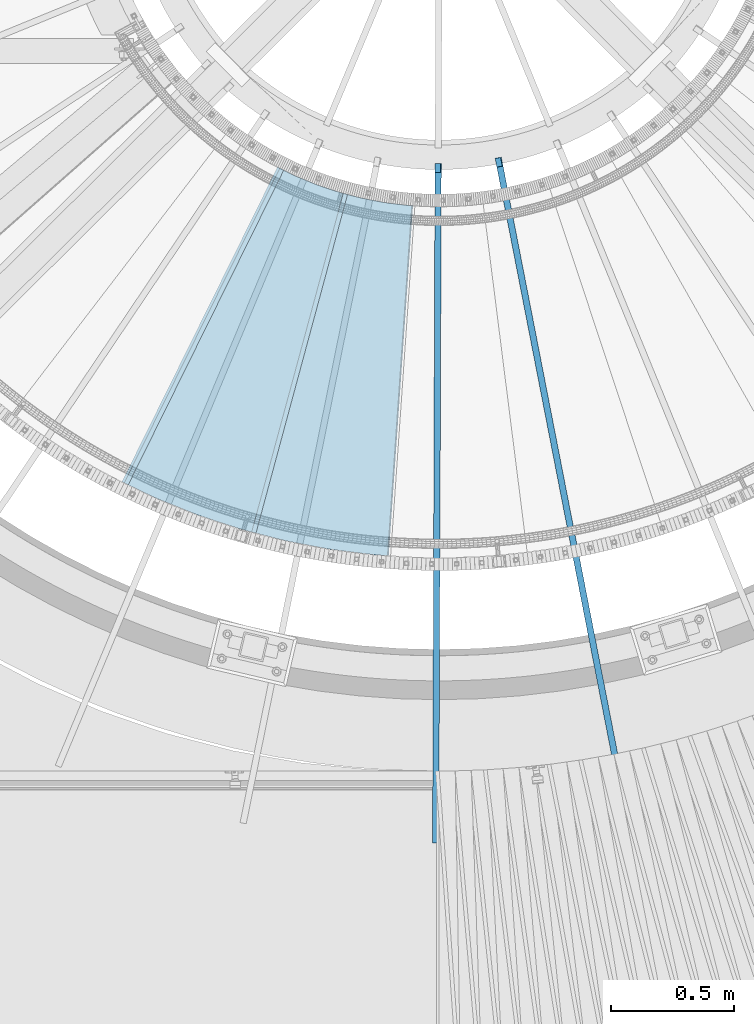
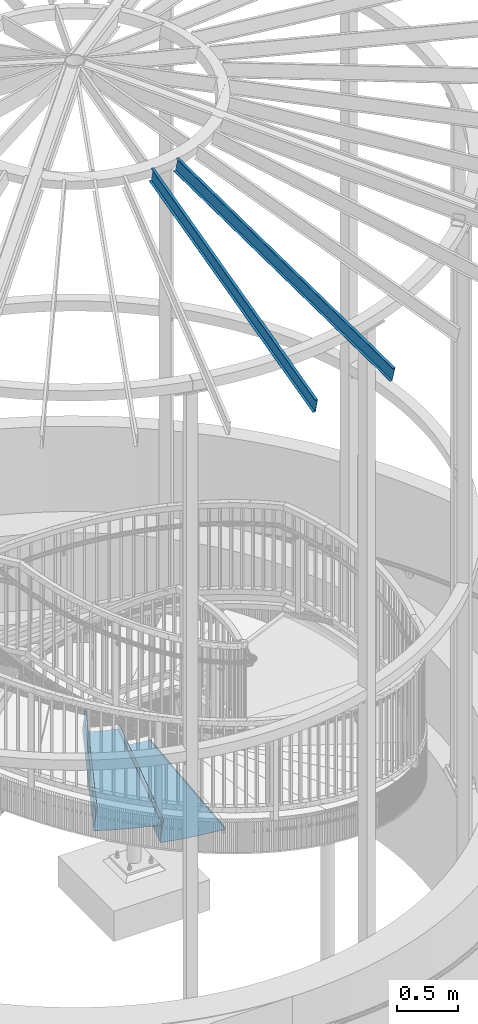
# One storey, part 340 of 975: 4 beams.
"""IFC2X3 building model written with IfcOpenShell, lengths in millimetres."""

import ifcopenshell
import ifcopenshell.guid

model = None  # the IFC model being written
_history = None  # IfcOwnerHistory: only IFC2X3 demands one
_inside = {}  # id of a spatial element -> (the spatial element, [elements in it])
_under = {}  # id of a project, library or spatial element -> (it, [spatial elements below it])
_declared = {}  # id of a project -> (the project, [libraries it declares])
_typed = {}  # id of a type object -> (the type object, [elements of that type])
_made_of = {}  # id of a material, layer set ... -> (it, [elements and type objects made of it])


def new_model(schema):
    """Start an empty IFC model of exactly this schema.

    Asked for "IFC4X3", IfcOpenShell would pick the latest addendum, in which some entities
    have other attributes; the version numbers below select the first issue.
    IFC2X3 requires an IfcOwnerHistory on every rooted entity: one is made here for all.
    """
    global model, _history
    if schema == "IFC4X3":
        model = ifcopenshell.file(schema_version=(4, 3, 0, 0))
    else:
        model = ifcopenshell.file(schema=schema)
    _inside.clear()
    _under.clear()
    _declared.clear()
    _typed.clear()
    _made_of.clear()
    _history = None
    if model.schema == "IFC2X3":
        org = make("IfcOrganization", Name="unknown")
        user = make(
            "IfcPersonAndOrganization",
            ThePerson=make("IfcPerson", FamilyName="unknown"),
            TheOrganization=org,
        )
        app = make(
            "IfcApplication",
            ApplicationDeveloper=org,
            Version="unknown",
            ApplicationFullName="unknown",
            ApplicationIdentifier="unknown",
        )
        _history = make(
            "IfcOwnerHistory",
            OwningUser=user,
            OwningApplication=app,
            ChangeAction="ADDED",
            CreationDate=0,
        )
    return model


def make(cls, **values):
    """One entity of the class cls with the attributes given. An attribute that is None is left unset."""
    return model.create_entity(
        cls, **{name: value for name, value in values.items() if value is not None}
    )


def rooted(cls, **values):
    """An entity with a GlobalId (a new one), such as an element, a storey or a relation."""
    return make(cls, GlobalId=ifcopenshell.guid.new(), OwnerHistory=_history, **values)


def si_unit(unit_type, name, prefix=None):
    """IfcSIUnit, for example si_unit("LENGTHUNIT", "METRE", prefix="MILLI")."""
    return make("IfcSIUnit", UnitType=unit_type, Prefix=prefix, Name=name)


def assignment(units):
    """IfcUnitAssignment: the units of a project."""
    return None if units is None else make("IfcUnitAssignment", Units=units)


def point(xyz):
    """IfcCartesianPoint."""
    return None if xyz is None else make("IfcCartesianPoint", Coordinates=xyz)


def direction(xyz):
    """IfcDirection."""
    return None if xyz is None else make("IfcDirection", DirectionRatios=xyz)


def frame(location, z_axis=None, x_axis=None):
    """IfcAxis2Placement3D, a coordinate frame: its origin and axes. An axis left out is left unset."""
    return make(
        "IfcAxis2Placement3D",
        Location=point(location),
        Axis=direction(z_axis),
        RefDirection=direction(x_axis),
    )


def origin_with_axes():
    """The frame at (0, 0, 0) with the z axis (0, 0, 1) and the x axis (1, 0, 0) written out."""
    return frame((0.0, 0.0, 0.0), z_axis=(0.0, 0.0, 1.0), x_axis=(1.0, 0.0, 0.0))


def place(relative_to, where):
    """IfcLocalPlacement: puts the frame where relative to a parent placement (None: the world)."""
    return make(
        "IfcLocalPlacement", PlacementRelTo=relative_to, RelativePlacement=where
    )


def context(
    kind, dimensions, precision=None, world=None, true_north=None, identifier=None
):
    """IfcGeometricRepresentationContext, for example the 3D "Model" context."""
    return make(
        "IfcGeometricRepresentationContext",
        ContextIdentifier=identifier,
        ContextType=kind,
        CoordinateSpaceDimension=dimensions,
        Precision=precision,
        WorldCoordinateSystem=world,
        TrueNorth=true_north,
    )


def subcontext(parent, identifier, kind, view, scale=None):
    """IfcGeometricRepresentationSubContext, for example "Body" below "Model"."""
    return make(
        "IfcGeometricRepresentationSubContext",
        ContextIdentifier=identifier,
        ContextType=kind,
        ParentContext=parent,
        TargetScale=scale,
        TargetView=view,
    )


def project(units=None, contexts=None):
    """IfcProject with its units and contexts."""
    return rooted(
        "IfcProject",
        Name="project",
        RepresentationContexts=contexts,
        UnitsInContext=assignment(units),
    )


def spatial(cls, under=None, at=None, **own):
    """A site, building, storey or space (cls), placed at a placement, below another one or the project."""
    s = rooted(cls, ObjectPlacement=at, **own)
    if under is not None:
        _under.setdefault(under.id(), (under, []))[1].append(s)
    return s


def faces_of(points, faces, orient=None, outer=None):
    """IfcFace entities. A face is a list of loops; a loop is a list of indices into points, from 0.

    orient and outer hold one flag for each loop. By default every Orientation is true, the
    first loop of a face is its IfcFaceOuterBound and the others are IfcFaceBound.
    """
    made = []
    for i, loops in enumerate(faces):
        bounds = []
        for j, loop in enumerate(loops):
            is_outer = j == 0 if outer is None else outer[i][j]
            bounds.append(
                make(
                    "IfcFaceOuterBound" if is_outer else "IfcFaceBound",
                    Bound=make("IfcPolyLoop", Polygon=[points[k] for k in loop]),
                    Orientation=True if orient is None else orient[i][j],
                )
            )
        made.append(make("IfcFace", Bounds=bounds))
    return made


def faceted_brep(points, faces, orient=None, outer=None, voids=None):
    """IfcFacetedBrep: a solid bounded by flat faces; with voids (closed shells), ...WithVoids."""
    shared = [point(p) for p in points]
    hull = make("IfcClosedShell", CfsFaces=faces_of(shared, faces, orient, outer))
    if voids is None:
        return make("IfcFacetedBrep", Outer=hull)
    return make(
        "IfcFacetedBrepWithVoids",
        Outer=hull,
        Voids=[
            make(cls, CfsFaces=faces_of(shared, fs, o, b)) for cls, fs, o, b in voids
        ],
    )


def shape(context_of_items, identifier, shape_type, items):
    """IfcShapeRepresentation: the items that make up one representation, for example the "Body"."""
    return make(
        "IfcShapeRepresentation",
        ContextOfItems=context_of_items,
        RepresentationIdentifier=identifier,
        RepresentationType=shape_type,
        Items=items,
    )


def material(Name=None, Category=None):
    """IfcMaterial."""
    return make("IfcMaterial", Name=Name, Category=Category)


def made_of(thing, what):
    """Note that an element or type object is made of a material, layer set ...; save() writes the relation."""
    if what is not None:
        _made_of.setdefault(what.id(), (what, []))[1].append(thing)
    return thing


def type_object(cls, material=None, **own):
    """A type object (cls), such as IfcWallType, which elements share."""
    return made_of(rooted(cls, **own), material)


def element(
    cls,
    number,
    at=None,
    inside=None,
    cuts=None,
    type_object=None,
    material=None,
    context=None,
    identifier="Body",
    shape_type=None,
    held_by="IfcProductDefinitionShape",
    body=None,
    shapes=None,
    **own,
):
    """One element of the class cls, such as IfcWall. Its Tag is "e" and its number.

    at: its placement. inside: the storey or other place that contains it. cuts: it is an
    opening in that element (IfcRelVoidsElement). A single representation is given by context,
    identifier, shape_type and body (its items); several are given by shapes. held_by: the class
    of the entity that holds the representations. save() writes the other relations.
    """
    e = rooted(cls, Tag="e%d" % number, ObjectPlacement=at, **own)
    if body is not None:
        shapes = [shape(context, identifier, shape_type, body)]
    if shapes is not None:
        e.Representation = make(held_by, Representations=shapes)
    if inside is not None:
        _inside.setdefault(inside.id(), (inside, []))[1].append(e)
    if cuts is not None:
        rooted(
            "IfcRelVoidsElement", RelatingBuildingElement=cuts, RelatedOpeningElement=e
        )
    if type_object is not None:
        _typed.setdefault(type_object.id(), (type_object, []))[1].append(e)
    return made_of(e, material)


def aggregate(whole, parts):
    """IfcRelAggregates: a whole, such as a stair, and the parts it consists of."""
    return rooted("IfcRelAggregates", RelatingObject=whole, RelatedObjects=parts)


def save(model, path):
    """Write the relations noted so far, then the file.

    IfcRelAggregates (storeys below a building ...), IfcRelContainedInSpatialStructure (elements
    in a storey), IfcRelDefinesByType, IfcRelAssociatesMaterial and IfcRelDeclares: one each for
    every whole, place, type object, material and project.
    """
    for whole, parts in _under.values():
        aggregate(whole, parts)
    for where, things in _inside.values():
        rooted(
            "IfcRelContainedInSpatialStructure",
            RelatedElements=things,
            RelatingStructure=where,
        )
    for kind, things in _typed.values():
        rooted("IfcRelDefinesByType", RelatedObjects=things, RelatingType=kind)
    for what, things in _made_of.values():
        rooted("IfcRelAssociatesMaterial", RelatedObjects=things, RelatingMaterial=what)
    for by, libraries in _declared.values():
        rooted("IfcRelDeclares", RelatingContext=by, RelatedDefinitions=libraries)
    model.write(path)


model = new_model("IFC2X3")

# Units and contexts
model_context = context("Model", 3, precision=1e-05, world=origin_with_axes())
body_context = subcontext(model_context, "Body", "Model", "MODEL_VIEW")
ifc_project = project(units=[si_unit("LENGTHUNIT", "METRE", prefix="MILLI"), si_unit("AREAUNIT", "SQUARE_METRE"), si_unit("VOLUMEUNIT", "CUBIC_METRE"), si_unit("MASSUNIT", "GRAM", prefix="KILO"), si_unit("TIMEUNIT", "SECOND"), si_unit("PLANEANGLEUNIT", "RADIAN"), si_unit("SOLIDANGLEUNIT", "STERADIAN"), si_unit("THERMODYNAMICTEMPERATUREUNIT", "DEGREE_CELSIUS"), si_unit("LUMINOUSINTENSITYUNIT", "LUMEN")], contexts=[model_context])

# Site, building, storey
site_placement = place(None, origin_with_axes())
site = spatial("IfcSite", under=ifc_project, at=site_placement, CompositionType="ELEMENT")
building_placement = place(site_placement, origin_with_axes())
building = spatial("IfcBuilding", under=site, at=building_placement, Name="Undefined", CompositionType="ELEMENT")
storey_placement = place(building_placement, origin_with_axes())
storey = spatial("IfcBuildingStorey", under=building, at=storey_placement, Name="Undefined", CompositionType="ELEMENT", Elevation=0.0)

# Beams
ifc_material_1 = material(Name="STEEL/A36")
beam_type_1 = type_object("IfcBeamType", PredefinedType="NOTDEFINED")
beam_1_placement = place(storey_placement, frame((34146.4647596154, 1293.83260585637, 3536.91695574218), z_axis=(-0.261073150170006, -0.965319019941236, -1.79452854354167e-10), x_axis=(0.682583625077842, -0.184606595021067, 0.707106781080707)))
element("IfcBeam", 1, at=beam_1_placement, inside=storey, type_object=beam_type_1, material=ifc_material_1, Name="TREAD", context=body_context, shape_type="Brep", body=[
    faceted_brep([(25.4000001621371, 1.5874997143419, 653.28751700326), (1.61144271260127e-08, 1.58750000026703, 653.458911680114), (-1.96268956642598e-08, -1.58749999973588, 653.437487347819), (15.8745748038546, -1.5875001784334, 653.330368544412), (-120.373022221533, -103.76749224318, 653.560250726816), (-154.208562872085, -137.603032237963, 653.560249286144), (-49.0005534961238, -242.811041643061, 652.140399877677), (-46.7554894721361, -240.565977619684, 652.140399877557), (-149.718432901582, -137.603030988068, 653.529952160912), (-118.287540217565, -106.172138299769, 653.529952144057), (82.2634121742994, -374.075007349978, 638.193006315465), (84.508476198167, -371.829943326711, 638.193006315345), (212.601306559884, -504.412901568812, 612.134347567509), (214.846370562875, -502.167837565145, 612.134347570151), (261.055176792581, -530.596712595621, 601.111823144849), (259.197053542079, -528.103470062568, 601.754434690294), (248.701623596196, -536.023091227627, 602.134831213494), (248.362633442506, -540.174228440612, 601.571851715846), (250.921725105154, -538.24319290819, 601.479100122608), (25.4000001865188, 1.58749971376164, -768.618736200977), (-118.287540216395, -106.172138302336, -768.542582766611), (-149.718433278054, -137.603031368186, -768.542582749815), (-92.8426928760819, -194.478774201189, -768.783692225286), (-95.087756899542, -196.723838224048, -768.783692225159), (-154.208562871598, -137.603032235413, -768.533065523057), (-120.373022220361, -103.767492245748, -768.533065418116), (15.8745748282345, -1.58750017901184, -768.605275732323), (-1.58015609486029e-08, -1.58750000031432, -768.571627720263), (1.99397618416697e-08, 1.58749999968677, -768.564897939472), (-21.2434099455131, -266.078057151808, -776.330856581004), (-23.4884739689005, -268.323121174595, -776.330856580884), (49.7927349215133, -337.114201961485, -791.08236047571), (47.5476709198538, -339.35926596382, -791.082360478347), (66.437802308692, -335.979336534963, -793.502619428495), (56.3071310127107, -343.628597994977, -793.115412720523), (53.7487404151489, -345.560335457225, -793.01762786691), (54.0919957188744, -341.413461775162, -792.424099714608), (64.5845451579717, -333.490960101732, -792.825137753654)], [[[0, 1, 2, 3, 4, 5, 6, 7, 8, 9]], [[7, 6, 10, 11]], [[11, 10, 12, 13]], [[14, 15, 16, 13, 12, 17, 18]], [[19, 20, 21, 22, 23, 24, 25, 26, 27, 28]], [[29, 30, 23, 22]], [[31, 32, 30, 29]], [[33, 34, 35, 32, 31, 36, 37]], [[34, 33, 14, 18]], [[35, 34, 18, 17]], [[10, 6, 5, 24, 23, 30, 32, 35, 17, 12]], [[25, 24, 5, 4]], [[26, 25, 4, 3]], [[27, 26, 3, 2]], [[28, 27, 2, 1]], [[19, 28, 1, 0]], [[20, 19, 0, 9]], [[20, 9, 8, 21]], [[36, 31, 29, 22, 21, 8, 7, 11, 13, 16]], [[37, 36, 16, 15]], [[33, 37, 15, 14]]]),
])
beam_2_placement = place(storey_placement, frame((33749.1032886187, 1447.60991246768, 3714.71695574218), z_axis=(-0.443035963518502, -0.896503839941153, 4.05594164476498e-10), x_axis=(0.63392394493821, -0.313273733969491, 0.707106780931133)))
element("IfcBeam", 2, at=beam_2_placement, inside=storey, type_object=beam_type_1, material=ifc_material_1, Name="TREAD", context=body_context, shape_type="Brep", body=[
    faceted_brep([(25.4000001621371, 1.5874997143419, 653.28751700326), (1.61144271260127e-08, 1.58750000026703, 653.458911680114), (-1.96268956642598e-08, -1.58749999973588, 653.437487347819), (15.8745748038546, -1.5875001784334, 653.330368544412), (-120.373022221533, -103.76749224318, 653.560250726816), (-154.208562872085, -137.603032237963, 653.560249286144), (-49.0005534961238, -242.811041643061, 652.140399877677), (-46.7554894721361, -240.565977619684, 652.140399877557), (-149.718432901582, -137.603030988068, 653.529952160912), (-118.287540217565, -106.172138299769, 653.529952144057), (82.2634121742994, -374.075007349978, 638.193006315465), (84.508476198167, -371.829943326711, 638.193006315345), (212.601306559884, -504.412901568812, 612.134347567509), (214.846370562875, -502.167837565145, 612.134347570151), (261.055176792581, -530.596712595621, 601.111823144849), (259.197053542079, -528.103470062568, 601.754434690294), (248.701623596196, -536.023091227627, 602.134831213494), (248.362633442506, -540.174228440612, 601.571851715846), (250.921725105154, -538.24319290819, 601.479100122608), (25.4000001865188, 1.58749971376164, -768.618736200977), (-118.287540216395, -106.172138302336, -768.542582766611), (-149.718433278054, -137.603031368186, -768.542582749815), (-92.8426928760819, -194.478774201189, -768.783692225286), (-95.087756899542, -196.723838224048, -768.783692225159), (-154.208562871598, -137.603032235413, -768.533065523057), (-120.373022220361, -103.767492245748, -768.533065418116), (15.8745748282345, -1.58750017901184, -768.605275732323), (-1.58015609486029e-08, -1.58750000031432, -768.571627720263), (1.99397618416697e-08, 1.58749999968677, -768.564897939472), (-21.2434099455131, -266.078057151808, -776.330856581004), (-23.4884739689005, -268.323121174595, -776.330856580884), (49.7927349215133, -337.114201961485, -791.08236047571), (47.5476709198538, -339.35926596382, -791.082360478347), (66.437802308692, -335.979336534963, -793.502619428495), (56.3071310127107, -343.628597994977, -793.115412720523), (53.7487404151489, -345.560335457225, -793.01762786691), (54.0919957188744, -341.413461775162, -792.424099714608), (64.5845451579717, -333.490960101732, -792.825137753654)], [[[0, 1, 2, 3, 4, 5, 6, 7, 8, 9]], [[7, 6, 10, 11]], [[11, 10, 12, 13]], [[14, 15, 16, 13, 12, 17, 18]], [[19, 20, 21, 22, 23, 24, 25, 26, 27, 28]], [[29, 30, 23, 22]], [[31, 32, 30, 29]], [[33, 34, 35, 32, 31, 36, 37]], [[34, 33, 14, 18]], [[35, 34, 18, 17]], [[10, 6, 5, 24, 23, 30, 32, 35, 17, 12]], [[25, 24, 5, 4]], [[26, 25, 4, 3]], [[27, 26, 3, 2]], [[28, 27, 2, 1]], [[19, 28, 1, 0]], [[20, 19, 0, 9]], [[20, 9, 8, 21]], [[36, 31, 29, 22, 21, 8, 7, 11, 13, 16]], [[37, 36, 16, 15]], [[33, 37, 15, 14]]]),
])
ifc_material_2 = material(Name="STEEL/Zero_Density")
beam_type_2 = type_object("IfcBeamType", PredefinedType="NOTDEFINED")
for number, where, z_axis, x_axis, name in (
    (3, (34977.2001898814, 2161.47152099186, 8885.0313138005), (0.0464456919896693, -0.23805333194703, 0.970140922157455), (0.185777631923843, -0.952186998609668, -0.242541936900574), "STUD"),
    (4, (34730.2095288316, 2137.99021322183, 8885.0313138005), (-0.000888649999629706, -0.242540308898345, 0.970140922165782), (-0.00355450199805182, -0.970134410469095, -0.24254193686727), "STUD"),
):
    element("IfcBeam", number, at=place(storey_placement, frame(where, z_axis=z_axis, x_axis=x_axis)), inside=storey, type_object=beam_type_2, material=ifc_material_2, Name=name, context=body_context, shape_type="Brep", body=[
        faceted_brep([(-1.67347025126219e-10, 12.6999999998588, -76.2000000000985), (1.96450855582952e-10, 12.7000000001644, 76.2000000001021), (2798.98467503002, 12.7000000041553, 76.2000000028588), (2798.98467502966, 12.7000000038533, -76.1999999973427), (1.74622982740402e-10, -12.6999999998661, 76.2000000000985), (2798.98467503, -12.6999999958753, 76.2000000028534), (1.67347025126219e-10, -12.6999999998698, 73.0250000000947), (2798.98467502999, -12.6999999958789, 73.0250000028504), (1.89174897968769e-10, 9.52500000015425, 73.0250000000974), (2798.98467503001, 9.52500000414511, 73.0250000028532), (-1.60071067512035e-10, 9.52499999986321, -73.0250000000938), (2798.98467502966, 9.52500000385407, -73.0249999973398), (-1.81898940354586e-10, -12.7000000001608, -73.0250000000965), (2798.98467502964, -12.6999999961699, -73.0249999973416), (-1.92812876775861e-10, -12.7000000001717, -76.2000000001003), (2798.98467502963, -12.6999999961772, -76.1999999973455)], [[[0, 1, 2, 3]], [[1, 4, 5, 2]], [[4, 6, 7, 5]], [[6, 8, 9, 7]], [[8, 10, 11, 9]], [[10, 12, 13, 11]], [[12, 14, 15, 13]], [[14, 0, 3, 15]], [[5, 7, 9, 11, 13, 15, 3, 2]], [[14, 12, 10, 8, 6, 4, 1, 0]]]),
    ])

save(model, "model.ifc")
